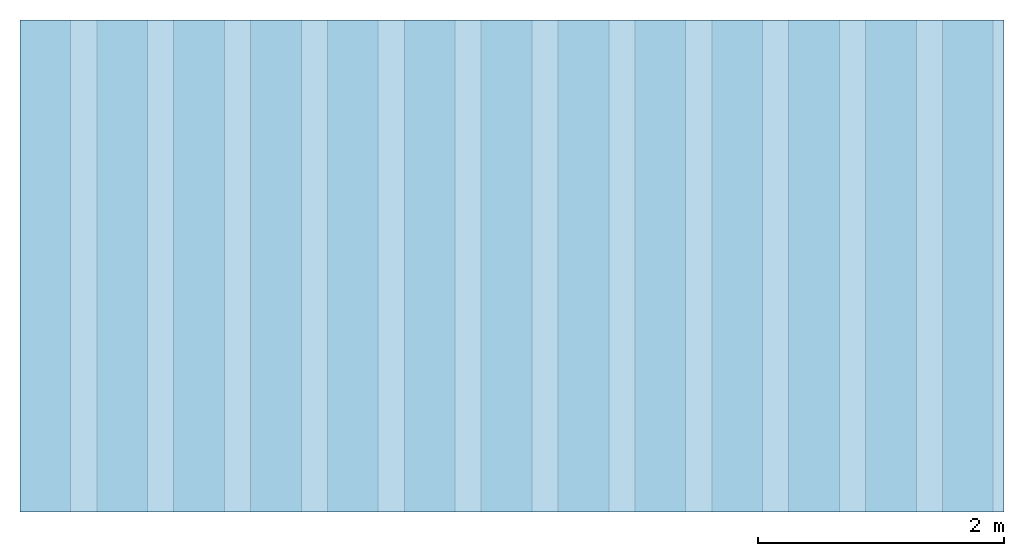
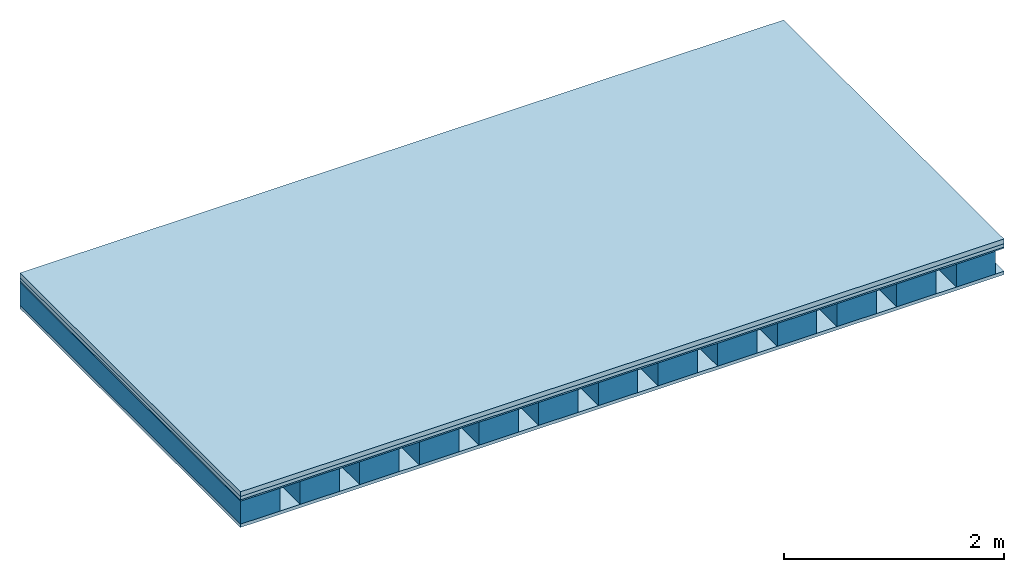
# One storey: 4 plates, 1 member, 1 element without a shape of its own.
"""IFC4 building model written with IfcOpenShell, lengths in metres."""

from ifc_helpers import new_model, si_unit, derived_unit, direction, frame, frame_2d, origin, origin_with_axes, place, context, project, spatial, rectangle, extrude, material, layer, layer_set, type_object, element, aggregate, save


model = new_model("IFC4")

# Units and contexts
plan_context = context("Plan", 3, precision=1e-05, world=origin(), true_north=direction((0.0, 1.0)))
model_context = context("Model", 3, precision=1e-05, world=origin(), true_north=direction((0.0, 1.0)))
ifc_project = project(units=[si_unit("LENGTHUNIT", "METRE"), derived_unit("SOUNDPRESSUREUNIT", [(si_unit("PRESSUREUNIT", "PASCAL", prefix="MICRO"), 0)]), si_unit("ENERGYUNIT", "JOULE", prefix="MEGA"), si_unit("MASSUNIT", "GRAM", prefix="KILO"), derived_unit("THERMALTRANSMITTANCEUNIT", [(si_unit("POWERUNIT", "WATT"), 1), (si_unit("AREAUNIT", "SQUARE_METRE"), -1), (si_unit("THERMODYNAMICTEMPERATUREUNIT", "KELVIN"), -1)]), derived_unit("AREADENSITYUNIT", [(si_unit("MASSUNIT", "GRAM", prefix="KILO"), 1), (si_unit("AREAUNIT", "SQUARE_METRE"), -1)]), derived_unit("USERDEFINED", [(si_unit("ENERGYUNIT", "JOULE", prefix="MEGA"), 1), (si_unit("AREAUNIT", "SQUARE_METRE"), -1)])], contexts=[plan_context, model_context])

# Site, building, storey
site = spatial("IfcSite", under=ifc_project)
building_placement = place(None, origin())
building = spatial("IfcBuilding", under=site, at=building_placement)
storey_placement = place(building_placement, origin())
storey = spatial("IfcBuildingStorey", under=building, at=storey_placement)

# Slab, member, plates
ifc_material_1 = material(Name="Cement screed", Category="04.006")
ifc_layer_1 = layer(ifc_material_1, 0.053, Name="On-material")
ifc_material_2 = material(Name="EP1, 40/35mm")
ifc_layer_2 = layer(ifc_material_2, 0.037, Name="Impact sound insulation")
ifc_material_3 = material(Name="Standard-n", Category="10.009")
ifc_layer_3 = layer(ifc_material_3, 0.015, Name="Additional insulation")
ifc_material_4 = material(Name="no composite action")
ifc_layer_4 = layer(ifc_material_4, 0.0, Name="Bond")
ifc_layer_5 = layer(None, 0.253, Name="Supporting structure")
ifc_material_5 = material(Name="Rigid, of the art")
ifc_layer_6 = layer(ifc_material_5, 0.0, Name="Bond")
ifc_material_6 = material(Name="panel on the underside HBF 37mm (17 + 20mm)", Category="07.001")
ifc_layer_7 = layer(ifc_material_6, 0.037, Name="Lower layer 1")
ifc_layer_set = layer_set([ifc_layer_1, ifc_layer_2, ifc_layer_3, ifc_layer_4, ifc_layer_5, ifc_layer_6, ifc_layer_7])
slab_type = type_object("IfcSlabType", Name="A0043", PredefinedType="NOTDEFINED", material=ifc_layer_set)
slab_placement = place(None, frame((0.0, 0.0, 0.0), z_axis=(0.0, 0.0, -1.0), x_axis=(1.0, 0.0, 0.0)))
slab = element("IfcSlab", 1, at=slab_placement, inside=storey, type_object=slab_type, material=ifc_layer_set, Name="Slab #1")
ifc_material_7 = material(Name="Ribs HBF")
member_placement = place(slab_placement, origin())
member = element("IfcMember", 2, at=member_placement, material=ifc_material_7, Name="Supporting structure", context=plan_context, shape_type="SweptSolid", body=[
    extrude(rectangle(XDim=0.4125, YDim=0.253, at=frame_2d((0.20625, 0.1265), x_axis=(1.0, 0.0))), frame((0.0, 4.0, 0.105), z_axis=(0.0, -1.0, 0.0), x_axis=(1.0, 0.0, 0.0)), (0.0, 0.0, 1.0), 4.0),
    extrude(rectangle(XDim=0.4125, YDim=0.253, at=frame_2d((0.20625, 0.1265), x_axis=(1.0, 0.0))), frame((0.625, 4.0, 0.105), z_axis=(0.0, -1.0, 0.0), x_axis=(1.0, 0.0, 0.0)), (0.0, 0.0, 1.0), 4.0),
    extrude(rectangle(XDim=0.4125, YDim=0.253, at=frame_2d((0.20625, 0.1265), x_axis=(1.0, 0.0))), frame((1.25, 4.0, 0.105), z_axis=(0.0, -1.0, 0.0), x_axis=(1.0, 0.0, 0.0)), (0.0, 0.0, 1.0), 4.0),
    extrude(rectangle(XDim=0.4125, YDim=0.253, at=frame_2d((0.20625, 0.1265), x_axis=(1.0, 0.0))), frame((1.875, 4.0, 0.105), z_axis=(0.0, -1.0, 0.0), x_axis=(1.0, 0.0, 0.0)), (0.0, 0.0, 1.0), 4.0),
    extrude(rectangle(XDim=0.4125, YDim=0.253, at=frame_2d((0.20625, 0.1265), x_axis=(1.0, 0.0))), frame((2.5, 4.0, 0.105), z_axis=(0.0, -1.0, 0.0), x_axis=(1.0, 0.0, 0.0)), (0.0, 0.0, 1.0), 4.0),
    extrude(rectangle(XDim=0.4125, YDim=0.253, at=frame_2d((0.20625, 0.1265), x_axis=(1.0, 0.0))), frame((3.125, 4.0, 0.105), z_axis=(0.0, -1.0, 0.0), x_axis=(1.0, 0.0, 0.0)), (0.0, 0.0, 1.0), 4.0),
    extrude(rectangle(XDim=0.4125, YDim=0.253, at=frame_2d((0.20625, 0.1265), x_axis=(1.0, 0.0))), frame((3.75, 4.0, 0.105), z_axis=(0.0, -1.0, 0.0), x_axis=(1.0, 0.0, 0.0)), (0.0, 0.0, 1.0), 4.0),
    extrude(rectangle(XDim=0.4125, YDim=0.253, at=frame_2d((0.20625, 0.1265), x_axis=(1.0, 0.0))), frame((4.375, 4.0, 0.105), z_axis=(0.0, -1.0, 0.0), x_axis=(1.0, 0.0, 0.0)), (0.0, 0.0, 1.0), 4.0),
    extrude(rectangle(XDim=0.4125, YDim=0.253, at=frame_2d((0.20625, 0.1265), x_axis=(1.0, 0.0))), frame((5.0, 4.0, 0.105), z_axis=(0.0, -1.0, 0.0), x_axis=(1.0, 0.0, 0.0)), (0.0, 0.0, 1.0), 4.0),
    extrude(rectangle(XDim=0.4125, YDim=0.253, at=frame_2d((0.20625, 0.1265), x_axis=(1.0, 0.0))), frame((5.625, 4.0, 0.105), z_axis=(0.0, -1.0, 0.0), x_axis=(1.0, 0.0, 0.0)), (0.0, 0.0, 1.0), 4.0),
    extrude(rectangle(XDim=0.4125, YDim=0.253, at=frame_2d((0.20625, 0.1265), x_axis=(1.0, 0.0))), frame((6.25, 4.0, 0.105), z_axis=(0.0, -1.0, 0.0), x_axis=(1.0, 0.0, 0.0)), (0.0, 0.0, 1.0), 4.0),
    extrude(rectangle(XDim=0.4125, YDim=0.253, at=frame_2d((0.20625, 0.1265), x_axis=(1.0, 0.0))), frame((6.875, 4.0, 0.105), z_axis=(0.0, -1.0, 0.0), x_axis=(1.0, 0.0, 0.0)), (0.0, 0.0, 1.0), 4.0),
    extrude(rectangle(XDim=0.4125, YDim=0.253, at=frame_2d((0.20625, 0.1265), x_axis=(1.0, 0.0))), frame((7.5, 4.0, 0.105), z_axis=(0.0, -1.0, 0.0), x_axis=(1.0, 0.0, 0.0)), (0.0, 0.0, 1.0), 4.0),
])
plate_1_placement = place(slab_placement, origin())
plate_1 = element("IfcPlate", 3, at=plate_1_placement, material=ifc_material_1, Name="On-material", context=plan_context, shape_type="SweptSolid", body=[
    extrude(rectangle(XDim=8.0, YDim=4.0, at=frame_2d((4.0, 2.0), x_axis=(1.0, 0.0))), origin_with_axes(), (0.0, 0.0, 1.0), 0.053),
])
plate_2_placement = place(slab_placement, origin())
plate_2 = element("IfcPlate", 4, at=plate_2_placement, material=ifc_material_2, Name="Impact sound insulation", context=plan_context, shape_type="SweptSolid", body=[
    extrude(rectangle(XDim=8.0, YDim=4.0, at=frame_2d((4.0, 2.0), x_axis=(1.0, 0.0))), frame((0.0, 0.0, 0.053), z_axis=(0.0, 0.0, 1.0), x_axis=(1.0, 0.0, 0.0)), (0.0, 0.0, 1.0), 0.037),
])
plate_3_placement = place(slab_placement, origin())
plate_3 = element("IfcPlate", 5, at=plate_3_placement, material=ifc_material_3, Name="Additional insulation", context=plan_context, shape_type="SweptSolid", body=[
    extrude(rectangle(XDim=8.0, YDim=4.0, at=frame_2d((4.0, 2.0), x_axis=(1.0, 0.0))), frame((0.0, 0.0, 0.09), z_axis=(0.0, 0.0, 1.0), x_axis=(1.0, 0.0, 0.0)), (0.0, 0.0, 1.0), 0.015),
])
plate_4_placement = place(slab_placement, origin())
plate_4 = element("IfcPlate", 6, at=plate_4_placement, material=ifc_material_6, Name="Lower layer 1", context=plan_context, shape_type="SweptSolid", body=[
    extrude(rectangle(XDim=8.0, YDim=4.0, at=frame_2d((4.0, 2.0), x_axis=(1.0, 0.0))), frame((0.0, 0.0, 0.358), z_axis=(0.0, 0.0, 1.0), x_axis=(1.0, 0.0, 0.0)), (0.0, 0.0, 1.0), 0.037),
])
aggregate(slab, [plate_1, plate_2, plate_3, member, plate_4])

save(model, "model.ifc")
